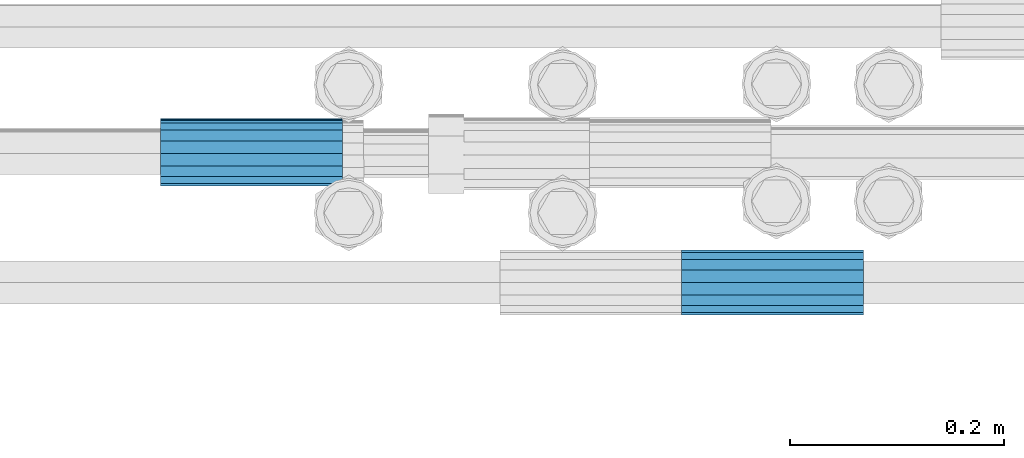
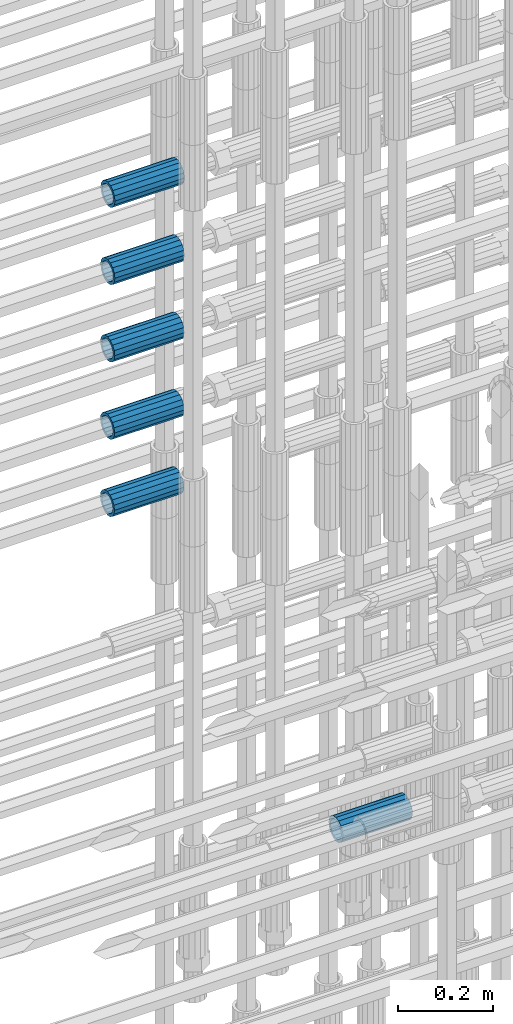
# One storey, part 43 of 119: 6 beams.
"""IFC2X3 building model written with IfcOpenShell, lengths in millimetres."""

from ifc_helpers import new_model, si_unit, frame, origin_with_axes, place, context, subcontext, project, spatial, faceted_brep, material, type_object, element, save


model = new_model("IFC2X3")

# Units and contexts
model_context = context("Model", 3, precision=1e-05, world=origin_with_axes())
body_context = subcontext(model_context, "Body", "Model", "MODEL_VIEW")
ifc_project = project(units=[si_unit("LENGTHUNIT", "METRE", prefix="MILLI"), si_unit("AREAUNIT", "SQUARE_METRE"), si_unit("VOLUMEUNIT", "CUBIC_METRE"), si_unit("MASSUNIT", "GRAM", prefix="KILO"), si_unit("TIMEUNIT", "SECOND"), si_unit("PLANEANGLEUNIT", "RADIAN"), si_unit("SOLIDANGLEUNIT", "STERADIAN"), si_unit("THERMODYNAMICTEMPERATUREUNIT", "DEGREE_CELSIUS"), si_unit("LUMINOUSINTENSITYUNIT", "LUMEN")], contexts=[model_context])

# Site, building, storey
site_placement = place(None, origin_with_axes())
site = spatial("IfcSite", under=ifc_project, at=site_placement, CompositionType="ELEMENT")
building_placement = place(site_placement, origin_with_axes())
building = spatial("IfcBuilding", under=site, at=building_placement, Name="Undefined", CompositionType="ELEMENT")
storey_placement = place(building_placement, origin_with_axes())
storey = spatial("IfcBuildingStorey", under=building, at=storey_placement, Name="Undefined", CompositionType="ELEMENT", Elevation=0.0)

# Beams
ifc_material = material(Name="STEEL/S275")
beam_type = type_object("IfcBeamType", PredefinedType="NOTDEFINED")
beam_1_placement = place(storey_placement, frame((2034949.03023304, 6206283.80994599, 19956.4894114171), z_axis=(0.0, 0.0, 1.0), x_axis=(1.0, 0.0, 0.0)))
element("IfcBeam", 1, at=beam_1_placement, inside=storey, type_object=beam_type, material=ifc_material, Name="AG40N", context=body_context, shape_type="Brep", body=[
    faceted_brep([(1.62981450557709e-09, -23.4999999990687, 0.0), (7.45058059692383e-09, -21.7111690142192, 8.99306066057534), (170.000002125278, -21.711168999318, 8.99306066022245), (170.000002127141, -23.4999999844003, -3.66071617463604e-10), (4.65661287307739e-09, -16.6170093587134, 16.6170093578889), (170.000002122484, -16.6170093440451, 16.6170093575288), (1.86264514923096e-09, -8.99306066217832, 21.7111690140277), (170.000002118759, -8.99306064750999, 21.7111690136603), (2.3283064365387e-10, 9.31322574615479e-10, 23.5), (170.000002114102, 1.28056854009628e-08, 23.4999999996485), (-6.51925802230835e-09, 8.99306065868586, 21.7111690140241), (170.00000211224, 8.99306067335419, 21.7111690136639), (-7.45058059692383e-09, 16.6170093561523, 16.6170093578853), (170.000002109446, 16.6170093708206, 16.6170093575324), (-9.31322574615479e-09, 21.711169013055, 8.99306066057534), (170.000002108514, 21.7111690277234, 8.99306066022245), (-1.16415321826935e-09, 23.5000000009313, 0.0), (170.000002108514, 23.5000000144355, -3.66071617463604e-10), (-8.38190317153931e-09, 21.7111690151505, -8.99306066059444), (170.000002110377, 21.7111690300517, -8.9930606609546), (-5.58793544769287e-09, 16.6170093598776, -16.6170093579008), (170.000002113171, 16.6170093745459, -16.6170093582609), (-9.31322574615479e-10, 8.99306066334248, -21.7111690140396), (170.000002115965, 8.99306067801081, -21.7111690143961), (2.3283064365387e-10, 9.31322574615479e-10, -23.5), (170.00000211969, 1.7927959561348e-08, -23.5000000003843), (5.58793544769287e-09, -8.99306065752171, -21.7111690140396), (170.000002123415, -8.99306064285338, -21.7111690143961), (8.38190317153931e-09, -16.6170093549881, -16.6170093579008), (170.000002125278, -16.6170093403198, -16.6170093582646), (9.31322574615479e-09, -21.7111690121237, -8.99306066059444), (170.000002127141, -21.7111689972226, -8.9930606609546), (1.11758708953857e-08, -30.4999999990687, -9.54969436861575e-12), (1.30385160446167e-08, -28.1783257392235, -11.6718446871514), (170.000002129003, -28.1783257243223, -11.6718446875116), (170.000002129935, -30.4999999841675, -3.66071617463604e-10), (1.02445483207703e-08, -21.5667568228673, -21.5667568262129), (170.000002128072, -21.566756808199, -21.5667568265694), (7.45058059692383e-09, -11.6718446831219, -28.1783257416196), (170.000002125278, -11.6718446684536, -28.1783257419834), (3.72529029846191e-09, 3.95812094211578e-09, -30.5000000000277), (170.00000211969, 1.83936208486557e-08, -30.5000000003879), (-9.31322574615479e-10, 11.6718446905725, -28.1783257416232), (170.000002115965, 11.6718447052408, -28.1783257419797), (-6.51925802230835e-09, 21.5667568286881, -21.5667568262093), (170.000002110377, 21.5667568433564, -21.5667568265694), (-9.31322574615479e-09, 28.178325742716, -11.6718446871478), (170.000002108514, 28.1783257573843, -11.6718446875079), (-1.21071934700012e-08, 30.5, -5.91171556152403e-12), (170.000002106652, 30.5000000144355, -3.62433638656512e-10), (-1.21071934700012e-08, 28.1783257401548, 11.6718446871359), (170.00000210572, 28.1783257548232, 11.6718446867794), (-1.02445483207703e-08, 21.5667568240315, 21.5667568261974), (170.000002107583, 21.566756838467, 21.5667568258409), (-7.45058059692383e-09, 11.671844684286, 28.1783257416041), (170.000002110377, 11.6718446989544, 28.178325741244), (-2.79396772384644e-09, -2.56113708019257e-09, 30.5000000000159), (170.000002114102, 1.18743628263474e-08, 30.4999999996558), (1.86264514923096e-09, -11.6718446896411, 28.1783257416114), (170.000002118759, -11.67184467474, 28.178325741244), (7.45058059692383e-09, -21.5667568275239, 21.5667568261974), (170.000002123415, -21.5667568126228, 21.5667568258373), (1.02445483207703e-08, -28.1783257415518, 11.6718446871359), (170.000002127141, -28.1783257271163, 11.6718446867794)], [[[0, 1, 2, 3]], [[1, 4, 5, 2]], [[4, 6, 7, 5]], [[6, 8, 9, 7]], [[8, 10, 11, 9]], [[10, 12, 13, 11]], [[12, 14, 15, 13]], [[14, 16, 17, 15]], [[16, 18, 19, 17]], [[18, 20, 21, 19]], [[20, 22, 23, 21]], [[22, 24, 25, 23]], [[24, 26, 27, 25]], [[26, 28, 29, 27]], [[28, 30, 31, 29]], [[30, 0, 3, 31]], [[32, 33, 34, 35]], [[33, 36, 37, 34]], [[36, 38, 39, 37]], [[38, 40, 41, 39]], [[40, 42, 43, 41]], [[42, 44, 45, 43]], [[44, 46, 47, 45]], [[46, 48, 49, 47]], [[48, 50, 51, 49]], [[50, 52, 53, 51]], [[52, 54, 55, 53]], [[54, 56, 57, 55]], [[56, 58, 59, 57]], [[58, 60, 61, 59]], [[60, 62, 63, 61]], [[62, 32, 35, 63]], [[37, 39, 41, 43, 45, 47, 49, 51, 53, 55, 57, 59, 61, 63, 35, 34], [5, 7, 9, 11, 13, 15, 17, 19, 21, 23, 25, 27, 29, 31, 3, 2]], [[62, 60, 58, 56, 54, 52, 50, 48, 46, 44, 42, 40, 38, 36, 33, 32], [30, 28, 26, 24, 22, 20, 18, 16, 14, 12, 10, 8, 6, 4, 1, 0]]]),
])
beam_2_placement = place(storey_placement, frame((2034949.03023304, 6206283.29994599, 20156.4794114617), z_axis=(0.0, 0.0, 1.0), x_axis=(1.0, 0.0, 0.0)))
element("IfcBeam", 2, at=beam_2_placement, inside=storey, type_object=beam_type, material=ifc_material, Name="AG40N", context=body_context, shape_type="Brep", body=[
    faceted_brep([(1.62981450557709e-09, -23.4999999990687, 0.0), (7.45058059692383e-09, -21.7111690142192, 8.99306066057534), (170.000002125278, -21.711168999318, 8.99306066022245), (170.000002127141, -23.4999999844003, -3.66071617463604e-10), (4.65661287307739e-09, -16.6170093587134, 16.6170093578889), (170.000002122484, -16.6170093440451, 16.6170093575288), (1.86264514923096e-09, -8.99306066217832, 21.7111690140277), (170.000002118759, -8.99306064750999, 21.7111690136603), (2.3283064365387e-10, 9.31322574615479e-10, 23.5), (170.000002114102, 1.28056854009628e-08, 23.4999999996485), (-6.51925802230835e-09, 8.99306065868586, 21.7111690140241), (170.00000211224, 8.99306067335419, 21.7111690136639), (-7.45058059692383e-09, 16.6170093561523, 16.6170093578853), (170.000002109446, 16.6170093708206, 16.6170093575324), (-9.31322574615479e-09, 21.711169013055, 8.99306066057534), (170.000002108514, 21.7111690277234, 8.99306066022245), (-1.16415321826935e-09, 23.5000000009313, 0.0), (170.000002108514, 23.5000000144355, -3.66071617463604e-10), (-8.38190317153931e-09, 21.7111690151505, -8.99306066059444), (170.000002110377, 21.7111690300517, -8.9930606609546), (-5.58793544769287e-09, 16.6170093598776, -16.6170093579008), (170.000002113171, 16.6170093745459, -16.6170093582609), (-9.31322574615479e-10, 8.99306066334248, -21.7111690140396), (170.000002115965, 8.99306067801081, -21.7111690143961), (2.3283064365387e-10, 9.31322574615479e-10, -23.5), (170.00000211969, 1.7927959561348e-08, -23.5000000003843), (5.58793544769287e-09, -8.99306065752171, -21.7111690140396), (170.000002123415, -8.99306064285338, -21.7111690143961), (8.38190317153931e-09, -16.6170093549881, -16.6170093579008), (170.000002125278, -16.6170093403198, -16.6170093582646), (9.31322574615479e-09, -21.7111690121237, -8.99306066059444), (170.000002127141, -21.7111689972226, -8.9930606609546), (1.11758708953857e-08, -30.4999999990687, -9.54969436861575e-12), (1.30385160446167e-08, -28.1783257392235, -11.6718446871514), (170.000002129003, -28.1783257243223, -11.6718446875116), (170.000002129935, -30.4999999841675, -3.66071617463604e-10), (1.02445483207703e-08, -21.5667568228673, -21.5667568262129), (170.000002128072, -21.566756808199, -21.5667568265694), (7.45058059692383e-09, -11.6718446831219, -28.1783257416196), (170.000002125278, -11.6718446684536, -28.1783257419834), (3.72529029846191e-09, 3.95812094211578e-09, -30.5000000000277), (170.00000211969, 1.83936208486557e-08, -30.5000000003879), (-9.31322574615479e-10, 11.6718446905725, -28.1783257416232), (170.000002115965, 11.6718447052408, -28.1783257419797), (-6.51925802230835e-09, 21.5667568286881, -21.5667568262093), (170.000002110377, 21.5667568433564, -21.5667568265694), (-9.31322574615479e-09, 28.178325742716, -11.6718446871478), (170.000002108514, 28.1783257573843, -11.6718446875079), (-1.21071934700012e-08, 30.5, -5.91171556152403e-12), (170.000002106652, 30.5000000144355, -3.62433638656512e-10), (-1.21071934700012e-08, 28.1783257401548, 11.6718446871359), (170.00000210572, 28.1783257548232, 11.6718446867794), (-1.02445483207703e-08, 21.5667568240315, 21.5667568261974), (170.000002107583, 21.566756838467, 21.5667568258409), (-7.45058059692383e-09, 11.671844684286, 28.1783257416041), (170.000002110377, 11.6718446989544, 28.178325741244), (-2.79396772384644e-09, -2.56113708019257e-09, 30.5000000000159), (170.000002114102, 1.18743628263474e-08, 30.4999999996558), (1.86264514923096e-09, -11.6718446896411, 28.1783257416114), (170.000002118759, -11.67184467474, 28.178325741244), (7.45058059692383e-09, -21.5667568275239, 21.5667568261974), (170.000002123415, -21.5667568126228, 21.5667568258373), (1.02445483207703e-08, -28.1783257415518, 11.6718446871359), (170.000002127141, -28.1783257271163, 11.6718446867794)], [[[0, 1, 2, 3]], [[1, 4, 5, 2]], [[4, 6, 7, 5]], [[6, 8, 9, 7]], [[8, 10, 11, 9]], [[10, 12, 13, 11]], [[12, 14, 15, 13]], [[14, 16, 17, 15]], [[16, 18, 19, 17]], [[18, 20, 21, 19]], [[20, 22, 23, 21]], [[22, 24, 25, 23]], [[24, 26, 27, 25]], [[26, 28, 29, 27]], [[28, 30, 31, 29]], [[30, 0, 3, 31]], [[32, 33, 34, 35]], [[33, 36, 37, 34]], [[36, 38, 39, 37]], [[38, 40, 41, 39]], [[40, 42, 43, 41]], [[42, 44, 45, 43]], [[44, 46, 47, 45]], [[46, 48, 49, 47]], [[48, 50, 51, 49]], [[50, 52, 53, 51]], [[52, 54, 55, 53]], [[54, 56, 57, 55]], [[56, 58, 59, 57]], [[58, 60, 61, 59]], [[60, 62, 63, 61]], [[62, 32, 35, 63]], [[37, 39, 41, 43, 45, 47, 49, 51, 53, 55, 57, 59, 61, 63, 35, 34], [5, 7, 9, 11, 13, 15, 17, 19, 21, 23, 25, 27, 29, 31, 3, 2]], [[62, 60, 58, 56, 54, 52, 50, 48, 46, 44, 42, 40, 38, 36, 33, 32], [30, 28, 26, 24, 22, 20, 18, 16, 14, 12, 10, 8, 6, 4, 1, 0]]]),
])
beam_3_placement = place(storey_placement, frame((2034949.03023304, 6206282.79994599, 20356.4894113726), z_axis=(0.0, 0.0, 1.0), x_axis=(1.0, 0.0, 0.0)))
element("IfcBeam", 3, at=beam_3_placement, inside=storey, type_object=beam_type, material=ifc_material, Name="AG40N", context=body_context, shape_type="Brep", body=[
    faceted_brep([(1.62981450557709e-09, -23.4999999990687, 0.0), (7.45058059692383e-09, -21.7111690142192, 8.99306066057534), (170.000002125278, -21.711168999318, 8.99306066022245), (170.000002127141, -23.4999999844003, -3.66071617463604e-10), (4.65661287307739e-09, -16.6170093587134, 16.6170093578889), (170.000002122484, -16.6170093440451, 16.6170093575288), (1.86264514923096e-09, -8.99306066217832, 21.7111690140277), (170.000002118759, -8.99306064750999, 21.7111690136603), (2.3283064365387e-10, 9.31322574615479e-10, 23.5), (170.000002114102, 1.28056854009628e-08, 23.4999999996485), (-6.51925802230835e-09, 8.99306065868586, 21.7111690140241), (170.00000211224, 8.99306067335419, 21.7111690136639), (-7.45058059692383e-09, 16.6170093561523, 16.6170093578853), (170.000002109446, 16.6170093708206, 16.6170093575324), (-9.31322574615479e-09, 21.711169013055, 8.99306066057534), (170.000002108514, 21.7111690277234, 8.99306066022245), (-1.16415321826935e-09, 23.5000000009313, 0.0), (170.000002108514, 23.5000000144355, -3.66071617463604e-10), (-8.38190317153931e-09, 21.7111690151505, -8.99306066059444), (170.000002110377, 21.7111690300517, -8.9930606609546), (-5.58793544769287e-09, 16.6170093598776, -16.6170093579008), (170.000002113171, 16.6170093745459, -16.6170093582609), (-9.31322574615479e-10, 8.99306066334248, -21.7111690140396), (170.000002115965, 8.99306067801081, -21.7111690143961), (2.3283064365387e-10, 9.31322574615479e-10, -23.5), (170.00000211969, 1.7927959561348e-08, -23.5000000003843), (5.58793544769287e-09, -8.99306065752171, -21.7111690140396), (170.000002123415, -8.99306064285338, -21.7111690143961), (8.38190317153931e-09, -16.6170093549881, -16.6170093579008), (170.000002125278, -16.6170093403198, -16.6170093582646), (9.31322574615479e-09, -21.7111690121237, -8.99306066059444), (170.000002127141, -21.7111689972226, -8.9930606609546), (1.11758708953857e-08, -30.4999999990687, -9.54969436861575e-12), (1.30385160446167e-08, -28.1783257392235, -11.6718446871514), (170.000002129003, -28.1783257243223, -11.6718446875116), (170.000002129935, -30.4999999841675, -3.66071617463604e-10), (1.02445483207703e-08, -21.5667568228673, -21.5667568262129), (170.000002128072, -21.566756808199, -21.5667568265694), (7.45058059692383e-09, -11.6718446831219, -28.1783257416196), (170.000002125278, -11.6718446684536, -28.1783257419834), (3.72529029846191e-09, 3.95812094211578e-09, -30.5000000000277), (170.00000211969, 1.83936208486557e-08, -30.5000000003879), (-9.31322574615479e-10, 11.6718446905725, -28.1783257416232), (170.000002115965, 11.6718447052408, -28.1783257419797), (-6.51925802230835e-09, 21.5667568286881, -21.5667568262093), (170.000002110377, 21.5667568433564, -21.5667568265694), (-9.31322574615479e-09, 28.178325742716, -11.6718446871478), (170.000002108514, 28.1783257573843, -11.6718446875079), (-1.21071934700012e-08, 30.5, -5.91171556152403e-12), (170.000002106652, 30.5000000144355, -3.62433638656512e-10), (-1.21071934700012e-08, 28.1783257401548, 11.6718446871359), (170.00000210572, 28.1783257548232, 11.6718446867794), (-1.02445483207703e-08, 21.5667568240315, 21.5667568261974), (170.000002107583, 21.566756838467, 21.5667568258409), (-7.45058059692383e-09, 11.671844684286, 28.1783257416041), (170.000002110377, 11.6718446989544, 28.178325741244), (-2.79396772384644e-09, -2.56113708019257e-09, 30.5000000000159), (170.000002114102, 1.18743628263474e-08, 30.4999999996558), (1.86264514923096e-09, -11.6718446896411, 28.1783257416114), (170.000002118759, -11.67184467474, 28.178325741244), (7.45058059692383e-09, -21.5667568275239, 21.5667568261974), (170.000002123415, -21.5667568126228, 21.5667568258373), (1.02445483207703e-08, -28.1783257415518, 11.6718446871359), (170.000002127141, -28.1783257271163, 11.6718446867794)], [[[0, 1, 2, 3]], [[1, 4, 5, 2]], [[4, 6, 7, 5]], [[6, 8, 9, 7]], [[8, 10, 11, 9]], [[10, 12, 13, 11]], [[12, 14, 15, 13]], [[14, 16, 17, 15]], [[16, 18, 19, 17]], [[18, 20, 21, 19]], [[20, 22, 23, 21]], [[22, 24, 25, 23]], [[24, 26, 27, 25]], [[26, 28, 29, 27]], [[28, 30, 31, 29]], [[30, 0, 3, 31]], [[32, 33, 34, 35]], [[33, 36, 37, 34]], [[36, 38, 39, 37]], [[38, 40, 41, 39]], [[40, 42, 43, 41]], [[42, 44, 45, 43]], [[44, 46, 47, 45]], [[46, 48, 49, 47]], [[48, 50, 51, 49]], [[50, 52, 53, 51]], [[52, 54, 55, 53]], [[54, 56, 57, 55]], [[56, 58, 59, 57]], [[58, 60, 61, 59]], [[60, 62, 63, 61]], [[62, 32, 35, 63]], [[37, 39, 41, 43, 45, 47, 49, 51, 53, 55, 57, 59, 61, 63, 35, 34], [5, 7, 9, 11, 13, 15, 17, 19, 21, 23, 25, 27, 29, 31, 3, 2]], [[62, 60, 58, 56, 54, 52, 50, 48, 46, 44, 42, 40, 38, 36, 33, 32], [30, 28, 26, 24, 22, 20, 18, 16, 14, 12, 10, 8, 6, 4, 1, 0]]]),
])
beam_4_placement = place(storey_placement, frame((2034949.03023304, 6206282.29994599, 20556.4794113726), z_axis=(0.0, 0.0, 1.0), x_axis=(1.0, 0.0, 0.0)))
element("IfcBeam", 4, at=beam_4_placement, inside=storey, type_object=beam_type, material=ifc_material, Name="AG40N", context=body_context, shape_type="Brep", body=[
    faceted_brep([(1.62981450557709e-09, -23.4999999990687, 0.0), (7.45058059692383e-09, -21.7111690142192, 8.99306066057534), (170.000002125278, -21.711168999318, 8.99306066022245), (170.000002127141, -23.4999999844003, -3.66071617463604e-10), (4.65661287307739e-09, -16.6170093587134, 16.6170093578889), (170.000002122484, -16.6170093440451, 16.6170093575288), (1.86264514923096e-09, -8.99306066217832, 21.7111690140277), (170.000002118759, -8.99306064750999, 21.7111690136603), (2.3283064365387e-10, 9.31322574615479e-10, 23.5), (170.000002114102, 1.28056854009628e-08, 23.4999999996485), (-6.51925802230835e-09, 8.99306065868586, 21.7111690140241), (170.00000211224, 8.99306067335419, 21.7111690136639), (-7.45058059692383e-09, 16.6170093561523, 16.6170093578853), (170.000002109446, 16.6170093708206, 16.6170093575324), (-9.31322574615479e-09, 21.711169013055, 8.99306066057534), (170.000002108514, 21.7111690277234, 8.99306066022245), (-1.16415321826935e-09, 23.5000000009313, 0.0), (170.000002108514, 23.5000000144355, -3.66071617463604e-10), (-8.38190317153931e-09, 21.7111690151505, -8.99306066059444), (170.000002110377, 21.7111690300517, -8.9930606609546), (-5.58793544769287e-09, 16.6170093598776, -16.6170093579008), (170.000002113171, 16.6170093745459, -16.6170093582609), (-9.31322574615479e-10, 8.99306066334248, -21.7111690140396), (170.000002115965, 8.99306067801081, -21.7111690143961), (2.3283064365387e-10, 9.31322574615479e-10, -23.5), (170.00000211969, 1.7927959561348e-08, -23.5000000003843), (5.58793544769287e-09, -8.99306065752171, -21.7111690140396), (170.000002123415, -8.99306064285338, -21.7111690143961), (8.38190317153931e-09, -16.6170093549881, -16.6170093579008), (170.000002125278, -16.6170093403198, -16.6170093582646), (9.31322574615479e-09, -21.7111690121237, -8.99306066059444), (170.000002127141, -21.7111689972226, -8.9930606609546), (1.11758708953857e-08, -30.4999999990687, -9.54969436861575e-12), (1.30385160446167e-08, -28.1783257392235, -11.6718446871514), (170.000002129003, -28.1783257243223, -11.6718446875116), (170.000002129935, -30.4999999841675, -3.66071617463604e-10), (1.02445483207703e-08, -21.5667568228673, -21.5667568262129), (170.000002128072, -21.566756808199, -21.5667568265694), (7.45058059692383e-09, -11.6718446831219, -28.1783257416196), (170.000002125278, -11.6718446684536, -28.1783257419834), (3.72529029846191e-09, 3.95812094211578e-09, -30.5000000000277), (170.00000211969, 1.83936208486557e-08, -30.5000000003879), (-9.31322574615479e-10, 11.6718446905725, -28.1783257416232), (170.000002115965, 11.6718447052408, -28.1783257419797), (-6.51925802230835e-09, 21.5667568286881, -21.5667568262093), (170.000002110377, 21.5667568433564, -21.5667568265694), (-9.31322574615479e-09, 28.178325742716, -11.6718446871478), (170.000002108514, 28.1783257573843, -11.6718446875079), (-1.21071934700012e-08, 30.5, -5.91171556152403e-12), (170.000002106652, 30.5000000144355, -3.62433638656512e-10), (-1.21071934700012e-08, 28.1783257401548, 11.6718446871359), (170.00000210572, 28.1783257548232, 11.6718446867794), (-1.02445483207703e-08, 21.5667568240315, 21.5667568261974), (170.000002107583, 21.566756838467, 21.5667568258409), (-7.45058059692383e-09, 11.671844684286, 28.1783257416041), (170.000002110377, 11.6718446989544, 28.178325741244), (-2.79396772384644e-09, -2.56113708019257e-09, 30.5000000000159), (170.000002114102, 1.18743628263474e-08, 30.4999999996558), (1.86264514923096e-09, -11.6718446896411, 28.1783257416114), (170.000002118759, -11.67184467474, 28.178325741244), (7.45058059692383e-09, -21.5667568275239, 21.5667568261974), (170.000002123415, -21.5667568126228, 21.5667568258373), (1.02445483207703e-08, -28.1783257415518, 11.6718446871359), (170.000002127141, -28.1783257271163, 11.6718446867794)], [[[0, 1, 2, 3]], [[1, 4, 5, 2]], [[4, 6, 7, 5]], [[6, 8, 9, 7]], [[8, 10, 11, 9]], [[10, 12, 13, 11]], [[12, 14, 15, 13]], [[14, 16, 17, 15]], [[16, 18, 19, 17]], [[18, 20, 21, 19]], [[20, 22, 23, 21]], [[22, 24, 25, 23]], [[24, 26, 27, 25]], [[26, 28, 29, 27]], [[28, 30, 31, 29]], [[30, 0, 3, 31]], [[32, 33, 34, 35]], [[33, 36, 37, 34]], [[36, 38, 39, 37]], [[38, 40, 41, 39]], [[40, 42, 43, 41]], [[42, 44, 45, 43]], [[44, 46, 47, 45]], [[46, 48, 49, 47]], [[48, 50, 51, 49]], [[50, 52, 53, 51]], [[52, 54, 55, 53]], [[54, 56, 57, 55]], [[56, 58, 59, 57]], [[58, 60, 61, 59]], [[60, 62, 63, 61]], [[62, 32, 35, 63]], [[37, 39, 41, 43, 45, 47, 49, 51, 53, 55, 57, 59, 61, 63, 35, 34], [5, 7, 9, 11, 13, 15, 17, 19, 21, 23, 25, 27, 29, 31, 3, 2]], [[62, 60, 58, 56, 54, 52, 50, 48, 46, 44, 42, 40, 38, 36, 33, 32], [30, 28, 26, 24, 22, 20, 18, 16, 14, 12, 10, 8, 6, 4, 1, 0]]]),
])
beam_5_placement = place(storey_placement, frame((2034949.03023304, 6206281.80994599, 20756.4894113726), z_axis=(0.0, 0.0, 1.0), x_axis=(1.0, 0.0, 0.0)))
element("IfcBeam", 5, at=beam_5_placement, inside=storey, type_object=beam_type, material=ifc_material, Name="AG40N", context=body_context, shape_type="Brep", body=[
    faceted_brep([(1.62981450557709e-09, -23.4999999990687, 0.0), (7.45058059692383e-09, -21.7111690142192, 8.99306066057534), (170.000002125278, -21.711168999318, 8.99306066022245), (170.000002127141, -23.4999999844003, -3.66071617463604e-10), (4.65661287307739e-09, -16.6170093587134, 16.6170093578889), (170.000002122484, -16.6170093440451, 16.6170093575288), (1.86264514923096e-09, -8.99306066217832, 21.7111690140277), (170.000002118759, -8.99306064750999, 21.7111690136603), (2.3283064365387e-10, 9.31322574615479e-10, 23.5), (170.000002114102, 1.28056854009628e-08, 23.4999999996485), (-6.51925802230835e-09, 8.99306065868586, 21.7111690140241), (170.00000211224, 8.99306067335419, 21.7111690136639), (-7.45058059692383e-09, 16.6170093561523, 16.6170093578853), (170.000002109446, 16.6170093708206, 16.6170093575324), (-9.31322574615479e-09, 21.711169013055, 8.99306066057534), (170.000002108514, 21.7111690277234, 8.99306066022245), (-1.16415321826935e-09, 23.5000000009313, 0.0), (170.000002108514, 23.5000000144355, -3.66071617463604e-10), (-8.38190317153931e-09, 21.7111690151505, -8.99306066059444), (170.000002110377, 21.7111690300517, -8.9930606609546), (-5.58793544769287e-09, 16.6170093598776, -16.6170093579008), (170.000002113171, 16.6170093745459, -16.6170093582609), (-9.31322574615479e-10, 8.99306066334248, -21.7111690140396), (170.000002115965, 8.99306067801081, -21.7111690143961), (2.3283064365387e-10, 9.31322574615479e-10, -23.5), (170.00000211969, 1.7927959561348e-08, -23.5000000003843), (5.58793544769287e-09, -8.99306065752171, -21.7111690140396), (170.000002123415, -8.99306064285338, -21.7111690143961), (8.38190317153931e-09, -16.6170093549881, -16.6170093579008), (170.000002125278, -16.6170093403198, -16.6170093582646), (9.31322574615479e-09, -21.7111690121237, -8.99306066059444), (170.000002127141, -21.7111689972226, -8.9930606609546), (1.11758708953857e-08, -30.4999999990687, -9.54969436861575e-12), (1.30385160446167e-08, -28.1783257392235, -11.6718446871514), (170.000002129003, -28.1783257243223, -11.6718446875116), (170.000002129935, -30.4999999841675, -3.66071617463604e-10), (1.02445483207703e-08, -21.5667568228673, -21.5667568262129), (170.000002128072, -21.566756808199, -21.5667568265694), (7.45058059692383e-09, -11.6718446831219, -28.1783257416196), (170.000002125278, -11.6718446684536, -28.1783257419834), (3.72529029846191e-09, 3.95812094211578e-09, -30.5000000000277), (170.00000211969, 1.83936208486557e-08, -30.5000000003879), (-9.31322574615479e-10, 11.6718446905725, -28.1783257416232), (170.000002115965, 11.6718447052408, -28.1783257419797), (-6.51925802230835e-09, 21.5667568286881, -21.5667568262093), (170.000002110377, 21.5667568433564, -21.5667568265694), (-9.31322574615479e-09, 28.178325742716, -11.6718446871478), (170.000002108514, 28.1783257573843, -11.6718446875079), (-1.21071934700012e-08, 30.5, -5.91171556152403e-12), (170.000002106652, 30.5000000144355, -3.62433638656512e-10), (-1.21071934700012e-08, 28.1783257401548, 11.6718446871359), (170.00000210572, 28.1783257548232, 11.6718446867794), (-1.02445483207703e-08, 21.5667568240315, 21.5667568261974), (170.000002107583, 21.566756838467, 21.5667568258409), (-7.45058059692383e-09, 11.671844684286, 28.1783257416041), (170.000002110377, 11.6718446989544, 28.178325741244), (-2.79396772384644e-09, -2.56113708019257e-09, 30.5000000000159), (170.000002114102, 1.18743628263474e-08, 30.4999999996558), (1.86264514923096e-09, -11.6718446896411, 28.1783257416114), (170.000002118759, -11.67184467474, 28.178325741244), (7.45058059692383e-09, -21.5667568275239, 21.5667568261974), (170.000002123415, -21.5667568126228, 21.5667568258373), (1.02445483207703e-08, -28.1783257415518, 11.6718446871359), (170.000002127141, -28.1783257271163, 11.6718446867794)], [[[0, 1, 2, 3]], [[1, 4, 5, 2]], [[4, 6, 7, 5]], [[6, 8, 9, 7]], [[8, 10, 11, 9]], [[10, 12, 13, 11]], [[12, 14, 15, 13]], [[14, 16, 17, 15]], [[16, 18, 19, 17]], [[18, 20, 21, 19]], [[20, 22, 23, 21]], [[22, 24, 25, 23]], [[24, 26, 27, 25]], [[26, 28, 29, 27]], [[28, 30, 31, 29]], [[30, 0, 3, 31]], [[32, 33, 34, 35]], [[33, 36, 37, 34]], [[36, 38, 39, 37]], [[38, 40, 41, 39]], [[40, 42, 43, 41]], [[42, 44, 45, 43]], [[44, 46, 47, 45]], [[46, 48, 49, 47]], [[48, 50, 51, 49]], [[50, 52, 53, 51]], [[52, 54, 55, 53]], [[54, 56, 57, 55]], [[56, 58, 59, 57]], [[58, 60, 61, 59]], [[60, 62, 63, 61]], [[62, 32, 35, 63]], [[37, 39, 41, 43, 45, 47, 49, 51, 53, 55, 57, 59, 61, 63, 35, 34], [5, 7, 9, 11, 13, 15, 17, 19, 21, 23, 25, 27, 29, 31, 3, 2]], [[62, 60, 58, 56, 54, 52, 50, 48, 46, 44, 42, 40, 38, 36, 33, 32], [30, 28, 26, 24, 22, 20, 18, 16, 14, 12, 10, 8, 6, 4, 1, 0]]]),
])
beam_6_placement = place(storey_placement, frame((2035606.30007889, 6206160.98994599, 19018.4893125166), z_axis=(0.0, 0.0, 1.0), x_axis=(-0.99999999999998, 1.98000110685822e-07, 0.0)))
element("IfcBeam", 6, at=beam_6_placement, inside=storey, type_object=beam_type, material=ifc_material, Name="AG40N", context=body_context, shape_type="Brep", body=[
    faceted_brep([(1.62981450557709e-09, -23.4999999990687, 0.0), (7.45058059692383e-09, -21.7111690142192, 8.99306066057534), (170.000002125278, -21.711168999318, 8.99306066022245), (170.000002127141, -23.4999999844003, -3.66071617463604e-10), (4.65661287307739e-09, -16.6170093587134, 16.6170093578889), (170.000002122484, -16.6170093440451, 16.6170093575288), (1.86264514923096e-09, -8.99306066217832, 21.7111690140277), (170.000002118759, -8.99306064750999, 21.7111690136603), (2.3283064365387e-10, 9.31322574615479e-10, 23.5), (170.000002114102, 1.28056854009628e-08, 23.4999999996485), (-6.51925802230835e-09, 8.99306065868586, 21.7111690140241), (170.00000211224, 8.99306067335419, 21.7111690136639), (-7.45058059692383e-09, 16.6170093561523, 16.6170093578853), (170.000002109446, 16.6170093708206, 16.6170093575324), (-9.31322574615479e-09, 21.711169013055, 8.99306066057534), (170.000002108514, 21.7111690277234, 8.99306066022245), (-1.16415321826935e-09, 23.5000000009313, 0.0), (170.000002108514, 23.5000000144355, -3.66071617463604e-10), (-8.38190317153931e-09, 21.7111690151505, -8.99306066059444), (170.000002110377, 21.7111690300517, -8.9930606609546), (-5.58793544769287e-09, 16.6170093598776, -16.6170093579008), (170.000002113171, 16.6170093745459, -16.6170093582609), (-9.31322574615479e-10, 8.99306066334248, -21.7111690140396), (170.000002115965, 8.99306067801081, -21.7111690143961), (2.3283064365387e-10, 9.31322574615479e-10, -23.5), (170.00000211969, 1.7927959561348e-08, -23.5000000003843), (5.58793544769287e-09, -8.99306065752171, -21.7111690140396), (170.000002123415, -8.99306064285338, -21.7111690143961), (8.38190317153931e-09, -16.6170093549881, -16.6170093579008), (170.000002125278, -16.6170093403198, -16.6170093582646), (9.31322574615479e-09, -21.7111690121237, -8.99306066059444), (170.000002127141, -21.7111689972226, -8.9930606609546), (1.11758708953857e-08, -30.4999999990687, -9.54969436861575e-12), (1.30385160446167e-08, -28.1783257392235, -11.6718446871514), (170.000002129003, -28.1783257243223, -11.6718446875116), (170.000002129935, -30.4999999841675, -3.66071617463604e-10), (1.02445483207703e-08, -21.5667568228673, -21.5667568262129), (170.000002128072, -21.566756808199, -21.5667568265694), (7.45058059692383e-09, -11.6718446831219, -28.1783257416196), (170.000002125278, -11.6718446684536, -28.1783257419834), (3.72529029846191e-09, 3.95812094211578e-09, -30.5000000000277), (170.00000211969, 1.83936208486557e-08, -30.5000000003879), (-9.31322574615479e-10, 11.6718446905725, -28.1783257416232), (170.000002115965, 11.6718447052408, -28.1783257419797), (-6.51925802230835e-09, 21.5667568286881, -21.5667568262093), (170.000002110377, 21.5667568433564, -21.5667568265694), (-9.31322574615479e-09, 28.178325742716, -11.6718446871478), (170.000002108514, 28.1783257573843, -11.6718446875079), (-1.21071934700012e-08, 30.5, -5.91171556152403e-12), (170.000002106652, 30.5000000144355, -3.62433638656512e-10), (-1.21071934700012e-08, 28.1783257401548, 11.6718446871359), (170.00000210572, 28.1783257548232, 11.6718446867794), (-1.02445483207703e-08, 21.5667568240315, 21.5667568261974), (170.000002107583, 21.566756838467, 21.5667568258409), (-7.45058059692383e-09, 11.671844684286, 28.1783257416041), (170.000002110377, 11.6718446989544, 28.178325741244), (-2.79396772384644e-09, -2.56113708019257e-09, 30.5000000000159), (170.000002114102, 1.18743628263474e-08, 30.4999999996558), (1.86264514923096e-09, -11.6718446896411, 28.1783257416114), (170.000002118759, -11.67184467474, 28.178325741244), (7.45058059692383e-09, -21.5667568275239, 21.5667568261974), (170.000002123415, -21.5667568126228, 21.5667568258373), (1.02445483207703e-08, -28.1783257415518, 11.6718446871359), (170.000002127141, -28.1783257271163, 11.6718446867794)], [[[0, 1, 2, 3]], [[1, 4, 5, 2]], [[4, 6, 7, 5]], [[6, 8, 9, 7]], [[8, 10, 11, 9]], [[10, 12, 13, 11]], [[12, 14, 15, 13]], [[14, 16, 17, 15]], [[16, 18, 19, 17]], [[18, 20, 21, 19]], [[20, 22, 23, 21]], [[22, 24, 25, 23]], [[24, 26, 27, 25]], [[26, 28, 29, 27]], [[28, 30, 31, 29]], [[30, 0, 3, 31]], [[32, 33, 34, 35]], [[33, 36, 37, 34]], [[36, 38, 39, 37]], [[38, 40, 41, 39]], [[40, 42, 43, 41]], [[42, 44, 45, 43]], [[44, 46, 47, 45]], [[46, 48, 49, 47]], [[48, 50, 51, 49]], [[50, 52, 53, 51]], [[52, 54, 55, 53]], [[54, 56, 57, 55]], [[56, 58, 59, 57]], [[58, 60, 61, 59]], [[60, 62, 63, 61]], [[62, 32, 35, 63]], [[37, 39, 41, 43, 45, 47, 49, 51, 53, 55, 57, 59, 61, 63, 35, 34], [5, 7, 9, 11, 13, 15, 17, 19, 21, 23, 25, 27, 29, 31, 3, 2]], [[62, 60, 58, 56, 54, 52, 50, 48, 46, 44, 42, 40, 38, 36, 33, 32], [30, 28, 26, 24, 22, 20, 18, 16, 14, 12, 10, 8, 6, 4, 1, 0]]]),
])

save(model, "model.ifc")
